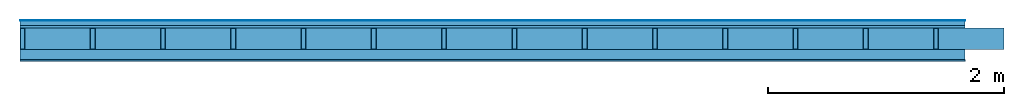
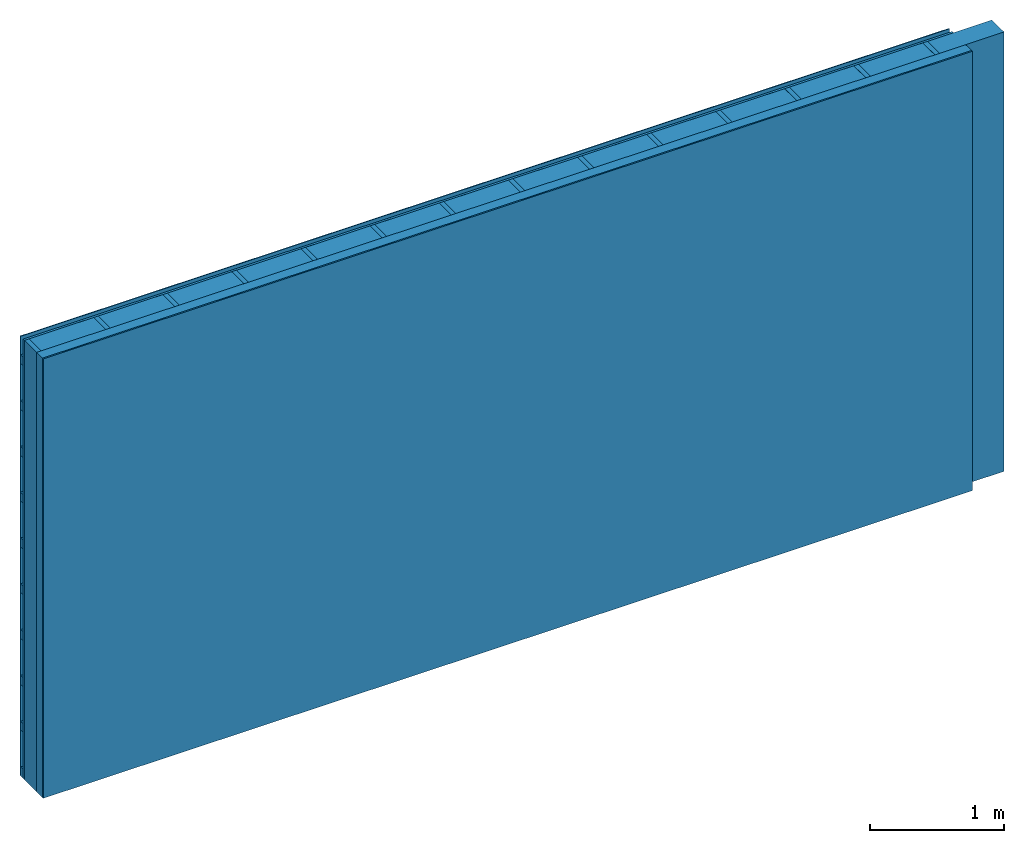
# One storey: 4 plates, 3 members, 1 element without a shape of its own.
"""IFC4 building model written with IfcOpenShell, lengths in metres."""

import ifcopenshell
import ifcopenshell.guid

model = None  # the IFC model being written
_history = None  # IfcOwnerHistory: only IFC2X3 demands one
_inside = {}  # id of a spatial element -> (the spatial element, [elements in it])
_under = {}  # id of a project, library or spatial element -> (it, [spatial elements below it])
_declared = {}  # id of a project -> (the project, [libraries it declares])
_typed = {}  # id of a type object -> (the type object, [elements of that type])
_made_of = {}  # id of a material, layer set ... -> (it, [elements and type objects made of it])


def new_model(schema):
    """Start an empty IFC model of exactly this schema.

    Asked for "IFC4X3", IfcOpenShell would pick the latest addendum, in which some entities
    have other attributes; the version numbers below select the first issue.
    IFC2X3 requires an IfcOwnerHistory on every rooted entity: one is made here for all.
    """
    global model, _history
    if schema == "IFC4X3":
        model = ifcopenshell.file(schema_version=(4, 3, 0, 0))
    else:
        model = ifcopenshell.file(schema=schema)
    _inside.clear()
    _under.clear()
    _declared.clear()
    _typed.clear()
    _made_of.clear()
    _history = None
    if model.schema == "IFC2X3":
        org = make("IfcOrganization", Name="unknown")
        user = make(
            "IfcPersonAndOrganization",
            ThePerson=make("IfcPerson", FamilyName="unknown"),
            TheOrganization=org,
        )
        app = make(
            "IfcApplication",
            ApplicationDeveloper=org,
            Version="unknown",
            ApplicationFullName="unknown",
            ApplicationIdentifier="unknown",
        )
        _history = make(
            "IfcOwnerHistory",
            OwningUser=user,
            OwningApplication=app,
            ChangeAction="ADDED",
            CreationDate=0,
        )
    return model


def make(cls, **values):
    """One entity of the class cls with the attributes given. An attribute that is None is left unset."""
    return model.create_entity(
        cls, **{name: value for name, value in values.items() if value is not None}
    )


def rooted(cls, **values):
    """An entity with a GlobalId (a new one), such as an element, a storey or a relation."""
    return make(cls, GlobalId=ifcopenshell.guid.new(), OwnerHistory=_history, **values)


def si_unit(unit_type, name, prefix=None):
    """IfcSIUnit, for example si_unit("LENGTHUNIT", "METRE", prefix="MILLI")."""
    return make("IfcSIUnit", UnitType=unit_type, Prefix=prefix, Name=name)


def derived_unit(unit_type, elements):
    """IfcDerivedUnit: a product of units, each with its exponent."""
    return make(
        "IfcDerivedUnit",
        Elements=[
            make("IfcDerivedUnitElement", Unit=unit, Exponent=power)
            for unit, power in elements
        ],
        UnitType=unit_type,
    )


def assignment(units):
    """IfcUnitAssignment: the units of a project."""
    return None if units is None else make("IfcUnitAssignment", Units=units)


def point(xyz):
    """IfcCartesianPoint."""
    return None if xyz is None else make("IfcCartesianPoint", Coordinates=xyz)


def direction(xyz):
    """IfcDirection."""
    return None if xyz is None else make("IfcDirection", DirectionRatios=xyz)


def frame(location, z_axis=None, x_axis=None):
    """IfcAxis2Placement3D, a coordinate frame: its origin and axes. An axis left out is left unset."""
    return make(
        "IfcAxis2Placement3D",
        Location=point(location),
        Axis=direction(z_axis),
        RefDirection=direction(x_axis),
    )


def frame_2d(location, x_axis=None):
    """IfcAxis2Placement2D, a coordinate frame in the plane: its origin and x axis."""
    return make(
        "IfcAxis2Placement2D", Location=point(location), RefDirection=direction(x_axis)
    )


def origin():
    """The frame at (0, 0, 0) with its axes left unset."""
    return frame((0.0, 0.0, 0.0))


def origin_with_axes():
    """The frame at (0, 0, 0) with the z axis (0, 0, 1) and the x axis (1, 0, 0) written out."""
    return frame((0.0, 0.0, 0.0), z_axis=(0.0, 0.0, 1.0), x_axis=(1.0, 0.0, 0.0))


def place(relative_to, where):
    """IfcLocalPlacement: puts the frame where relative to a parent placement (None: the world)."""
    return make(
        "IfcLocalPlacement", PlacementRelTo=relative_to, RelativePlacement=where
    )


def context(
    kind, dimensions, precision=None, world=None, true_north=None, identifier=None
):
    """IfcGeometricRepresentationContext, for example the 3D "Model" context."""
    return make(
        "IfcGeometricRepresentationContext",
        ContextIdentifier=identifier,
        ContextType=kind,
        CoordinateSpaceDimension=dimensions,
        Precision=precision,
        WorldCoordinateSystem=world,
        TrueNorth=true_north,
    )


def project(units=None, contexts=None):
    """IfcProject with its units and contexts."""
    return rooted(
        "IfcProject",
        Name="project",
        RepresentationContexts=contexts,
        UnitsInContext=assignment(units),
    )


def spatial(cls, under=None, at=None, **own):
    """A site, building, storey or space (cls), placed at a placement, below another one or the project."""
    s = rooted(cls, ObjectPlacement=at, **own)
    if under is not None:
        _under.setdefault(under.id(), (under, []))[1].append(s)
    return s


def profile(cls, at=None, kind="AREA", **sizes):
    """A parametric profile (cls). Its sizes go by their IFC names, for example OverallWidth=200.0."""
    return make(cls, ProfileType=kind, Position=at, **sizes)


def rectangle(**sizes):
    """IfcRectangleProfileDef."""
    return profile("IfcRectangleProfileDef", **sizes)


def extrude(swept, where, along, depth):
    """IfcExtrudedAreaSolid: the profile swept, set in the frame where, extruded along a direction by depth."""
    return make(
        "IfcExtrudedAreaSolid",
        SweptArea=swept,
        Position=where,
        ExtrudedDirection=direction(along),
        Depth=depth,
    )


def shape(context_of_items, identifier, shape_type, items):
    """IfcShapeRepresentation: the items that make up one representation, for example the "Body"."""
    return make(
        "IfcShapeRepresentation",
        ContextOfItems=context_of_items,
        RepresentationIdentifier=identifier,
        RepresentationType=shape_type,
        Items=items,
    )


def material(Name=None, Category=None):
    """IfcMaterial."""
    return make("IfcMaterial", Name=Name, Category=Category)


def layer(
    of_material, thickness, ventilated=None, Name=None, Category=None, Priority=None
):
    """IfcMaterialLayer: one layer of a wall or slab, of a material (None: an air gap)."""
    return make(
        "IfcMaterialLayer",
        Material=of_material,
        LayerThickness=thickness,
        IsVentilated=ventilated,
        Name=Name,
        Category=Category,
        Priority=Priority,
    )


def layer_set(layers, Name=None):
    """IfcMaterialLayerSet."""
    return make("IfcMaterialLayerSet", MaterialLayers=layers, LayerSetName=Name)


def made_of(thing, what):
    """Note that an element or type object is made of a material, layer set ...; save() writes the relation."""
    if what is not None:
        _made_of.setdefault(what.id(), (what, []))[1].append(thing)
    return thing


def type_object(cls, material=None, **own):
    """A type object (cls), such as IfcWallType, which elements share."""
    return made_of(rooted(cls, **own), material)


def element(
    cls,
    number,
    at=None,
    inside=None,
    cuts=None,
    type_object=None,
    material=None,
    context=None,
    identifier="Body",
    shape_type=None,
    held_by="IfcProductDefinitionShape",
    body=None,
    shapes=None,
    **own,
):
    """One element of the class cls, such as IfcWall. Its Tag is "e" and its number.

    at: its placement. inside: the storey or other place that contains it. cuts: it is an
    opening in that element (IfcRelVoidsElement). A single representation is given by context,
    identifier, shape_type and body (its items); several are given by shapes. held_by: the class
    of the entity that holds the representations. save() writes the other relations.
    """
    e = rooted(cls, Tag="e%d" % number, ObjectPlacement=at, **own)
    if body is not None:
        shapes = [shape(context, identifier, shape_type, body)]
    if shapes is not None:
        e.Representation = make(held_by, Representations=shapes)
    if inside is not None:
        _inside.setdefault(inside.id(), (inside, []))[1].append(e)
    if cuts is not None:
        rooted(
            "IfcRelVoidsElement", RelatingBuildingElement=cuts, RelatedOpeningElement=e
        )
    if type_object is not None:
        _typed.setdefault(type_object.id(), (type_object, []))[1].append(e)
    return made_of(e, material)


def aggregate(whole, parts):
    """IfcRelAggregates: a whole, such as a stair, and the parts it consists of."""
    return rooted("IfcRelAggregates", RelatingObject=whole, RelatedObjects=parts)


def save(model, path):
    """Write the relations noted so far, then the file.

    IfcRelAggregates (storeys below a building ...), IfcRelContainedInSpatialStructure (elements
    in a storey), IfcRelDefinesByType, IfcRelAssociatesMaterial and IfcRelDeclares: one each for
    every whole, place, type object, material and project.
    """
    for whole, parts in _under.values():
        aggregate(whole, parts)
    for where, things in _inside.values():
        rooted(
            "IfcRelContainedInSpatialStructure",
            RelatedElements=things,
            RelatingStructure=where,
        )
    for kind, things in _typed.values():
        rooted("IfcRelDefinesByType", RelatedObjects=things, RelatingType=kind)
    for what, things in _made_of.values():
        rooted("IfcRelAssociatesMaterial", RelatedObjects=things, RelatingMaterial=what)
    for by, libraries in _declared.values():
        rooted("IfcRelDeclares", RelatingContext=by, RelatedDefinitions=libraries)
    model.write(path)


model = new_model("IFC4")

# Units and contexts
plan_context = context("Plan", 3, precision=1e-05, world=origin(), true_north=direction((0.0, 1.0)))
model_context = context("Model", 3, precision=1e-05, world=origin(), true_north=direction((0.0, 1.0)))
ifc_project = project(units=[si_unit("LENGTHUNIT", "METRE"), derived_unit("SOUNDPRESSUREUNIT", [(si_unit("PRESSUREUNIT", "PASCAL", prefix="MICRO"), 0)]), si_unit("ENERGYUNIT", "JOULE", prefix="MEGA"), si_unit("MASSUNIT", "GRAM", prefix="KILO"), derived_unit("THERMALTRANSMITTANCEUNIT", [(si_unit("POWERUNIT", "WATT"), 1), (si_unit("AREAUNIT", "SQUARE_METRE"), -1), (si_unit("THERMODYNAMICTEMPERATUREUNIT", "KELVIN"), -1)]), derived_unit("AREADENSITYUNIT", [(si_unit("MASSUNIT", "GRAM", prefix="KILO"), 1), (si_unit("AREAUNIT", "SQUARE_METRE"), -1)]), derived_unit("USERDEFINED", [(si_unit("ENERGYUNIT", "JOULE", prefix="MEGA"), 1), (si_unit("AREAUNIT", "SQUARE_METRE"), -1)])], contexts=[plan_context, model_context])

# Site, building, storey
site = spatial("IfcSite", under=ifc_project)
building_placement = place(None, origin())
building = spatial("IfcBuilding", under=site, at=building_placement)
storey_placement = place(building_placement, origin())
storey = spatial("IfcBuildingStorey", under=building, at=storey_placement)

# Wall, members, plates
ifc_material_1 = material(Name="mineral, cement-based building board", Category="03.003")
ifc_layer_1 = layer(ifc_material_1, 0.008, Name="Cover 1st layer")
ifc_layer_2 = layer(None, 0.04, Name="Battens / profiles (ventilation)")
ifc_material_2 = material(Category="10.009")
ifc_layer_3 = layer(ifc_material_2, 0.02, Name="outside 1st layer")
ifc_material_3 = material(Name="of the art")
ifc_layer_4 = layer(ifc_material_3, 0.0, Name="Bond")
ifc_layer_5 = layer(None, 0.18, Name="Support")
ifc_layer_6 = layer(ifc_material_3, 0.0, Name="Bond")
ifc_material_4 = material(Name="Solid timber panel")
ifc_layer_7 = layer(ifc_material_4, 0.087, Name="1st layer")
ifc_material_5 = material(Name="Plasterboard type A", Category="03.008")
ifc_layer_8 = layer(ifc_material_5, 0.0125, Name="Covering 1st layer")
ifc_material_6 = material(Name="joints", Category="04.017")
ifc_layer_9 = layer(ifc_material_6, 0.0, Name="Surface")
ifc_layer_set = layer_set([ifc_layer_1, ifc_layer_2, ifc_layer_3, ifc_layer_4, ifc_layer_5, ifc_layer_6, ifc_layer_7, ifc_layer_8, ifc_layer_9])
wall_type = type_object("IfcWallType", Name="D0970", PredefinedType="NOTDEFINED", material=ifc_layer_set)
wall_placement = place(None, frame((0.0, 0.0, 0.0), z_axis=(0.0, -1.0, 0.0), x_axis=(1.0, 0.0, 0.0)))
wall = element("IfcWall", 1, at=wall_placement, inside=storey, type_object=wall_type, material=ifc_layer_set, Name="Wall #1")
ifc_material_7 = material()
member_1_placement = place(wall_placement, origin())
member_1 = element("IfcMember", 2, at=member_1_placement, material=ifc_material_7, Name="Battens / profiles (ventilation)", context=plan_context, shape_type="SweptSolid", body=[
    extrude(rectangle(XDim=0.08, YDim=0.04, at=frame_2d((0.04, 0.02), x_axis=(1.0, 0.0))), frame((0.0, 0.0, 0.008), z_axis=(1.0, 0.0, 0.0), x_axis=(0.0, 1.0, 0.0)), (0.0, 0.0, 1.0), 8.0),
    extrude(rectangle(XDim=0.08, YDim=0.04, at=frame_2d((0.04, 0.02), x_axis=(1.0, 0.0))), frame((0.0, 0.417, 0.008), z_axis=(1.0, 0.0, 0.0), x_axis=(0.0, 1.0, 0.0)), (0.0, 0.0, 1.0), 8.0),
    extrude(rectangle(XDim=0.08, YDim=0.04, at=frame_2d((0.04, 0.02), x_axis=(1.0, 0.0))), frame((0.0, 0.834, 0.008), z_axis=(1.0, 0.0, 0.0), x_axis=(0.0, 1.0, 0.0)), (0.0, 0.0, 1.0), 8.0),
    extrude(rectangle(XDim=0.08, YDim=0.04, at=frame_2d((0.04, 0.02), x_axis=(1.0, 0.0))), frame((0.0, 1.251, 0.008), z_axis=(1.0, 0.0, 0.0), x_axis=(0.0, 1.0, 0.0)), (0.0, 0.0, 1.0), 8.0),
    extrude(rectangle(XDim=0.08, YDim=0.04, at=frame_2d((0.04, 0.02), x_axis=(1.0, 0.0))), frame((0.0, 1.668, 0.008), z_axis=(1.0, 0.0, 0.0), x_axis=(0.0, 1.0, 0.0)), (0.0, 0.0, 1.0), 8.0),
    extrude(rectangle(XDim=0.08, YDim=0.04, at=frame_2d((0.04, 0.02), x_axis=(1.0, 0.0))), frame((0.0, 2.085, 0.008), z_axis=(1.0, 0.0, 0.0), x_axis=(0.0, 1.0, 0.0)), (0.0, 0.0, 1.0), 8.0),
    extrude(rectangle(XDim=0.08, YDim=0.04, at=frame_2d((0.04, 0.02), x_axis=(1.0, 0.0))), frame((0.0, 2.502, 0.008), z_axis=(1.0, 0.0, 0.0), x_axis=(0.0, 1.0, 0.0)), (0.0, 0.0, 1.0), 8.0),
    extrude(rectangle(XDim=0.08, YDim=0.04, at=frame_2d((0.04, 0.02), x_axis=(1.0, 0.0))), frame((0.0, 2.919, 0.008), z_axis=(1.0, 0.0, 0.0), x_axis=(0.0, 1.0, 0.0)), (0.0, 0.0, 1.0), 8.0),
    extrude(rectangle(XDim=0.08, YDim=0.04, at=frame_2d((0.04, 0.02), x_axis=(1.0, 0.0))), frame((0.0, 3.336, 0.008), z_axis=(1.0, 0.0, 0.0), x_axis=(0.0, 1.0, 0.0)), (0.0, 0.0, 1.0), 8.0),
    extrude(rectangle(XDim=0.08, YDim=0.04, at=frame_2d((0.04, 0.02), x_axis=(1.0, 0.0))), frame((0.0, 3.753, 0.008), z_axis=(1.0, 0.0, 0.0), x_axis=(0.0, 1.0, 0.0)), (0.0, 0.0, 1.0), 8.0),
])
ifc_material_8 = material()
member_2_placement = place(wall_placement, origin())
member_2 = element("IfcMember", 3, at=member_2_placement, material=ifc_material_8, Name="Support", context=plan_context, shape_type="SweptSolid", body=[
    extrude(rectangle(XDim=0.04, YDim=0.18, at=frame_2d((0.02, 0.09), x_axis=(1.0, 0.0))), frame((0.0, 4.0, 0.068), z_axis=(0.0, -1.0, 0.0), x_axis=(1.0, 0.0, 0.0)), (0.0, 0.0, 1.0), 4.0),
    extrude(rectangle(XDim=0.04, YDim=0.18, at=frame_2d((0.02, 0.09), x_axis=(1.0, 0.0))), frame((0.595, 4.0, 0.068), z_axis=(0.0, -1.0, 0.0), x_axis=(1.0, 0.0, 0.0)), (0.0, 0.0, 1.0), 4.0),
    extrude(rectangle(XDim=0.04, YDim=0.18, at=frame_2d((0.02, 0.09), x_axis=(1.0, 0.0))), frame((1.19, 4.0, 0.068), z_axis=(0.0, -1.0, 0.0), x_axis=(1.0, 0.0, 0.0)), (0.0, 0.0, 1.0), 4.0),
    extrude(rectangle(XDim=0.04, YDim=0.18, at=frame_2d((0.02, 0.09), x_axis=(1.0, 0.0))), frame((1.785, 4.0, 0.068), z_axis=(0.0, -1.0, 0.0), x_axis=(1.0, 0.0, 0.0)), (0.0, 0.0, 1.0), 4.0),
    extrude(rectangle(XDim=0.04, YDim=0.18, at=frame_2d((0.02, 0.09), x_axis=(1.0, 0.0))), frame((2.38, 4.0, 0.068), z_axis=(0.0, -1.0, 0.0), x_axis=(1.0, 0.0, 0.0)), (0.0, 0.0, 1.0), 4.0),
    extrude(rectangle(XDim=0.04, YDim=0.18, at=frame_2d((0.02, 0.09), x_axis=(1.0, 0.0))), frame((2.975, 4.0, 0.068), z_axis=(0.0, -1.0, 0.0), x_axis=(1.0, 0.0, 0.0)), (0.0, 0.0, 1.0), 4.0),
    extrude(rectangle(XDim=0.04, YDim=0.18, at=frame_2d((0.02, 0.09), x_axis=(1.0, 0.0))), frame((3.57, 4.0, 0.068), z_axis=(0.0, -1.0, 0.0), x_axis=(1.0, 0.0, 0.0)), (0.0, 0.0, 1.0), 4.0),
    extrude(rectangle(XDim=0.04, YDim=0.18, at=frame_2d((0.02, 0.09), x_axis=(1.0, 0.0))), frame((4.165, 4.0, 0.068), z_axis=(0.0, -1.0, 0.0), x_axis=(1.0, 0.0, 0.0)), (0.0, 0.0, 1.0), 4.0),
    extrude(rectangle(XDim=0.04, YDim=0.18, at=frame_2d((0.02, 0.09), x_axis=(1.0, 0.0))), frame((4.76, 4.0, 0.068), z_axis=(0.0, -1.0, 0.0), x_axis=(1.0, 0.0, 0.0)), (0.0, 0.0, 1.0), 4.0),
    extrude(rectangle(XDim=0.04, YDim=0.18, at=frame_2d((0.02, 0.09), x_axis=(1.0, 0.0))), frame((5.355, 4.0, 0.068), z_axis=(0.0, -1.0, 0.0), x_axis=(1.0, 0.0, 0.0)), (0.0, 0.0, 1.0), 4.0),
    extrude(rectangle(XDim=0.04, YDim=0.18, at=frame_2d((0.02, 0.09), x_axis=(1.0, 0.0))), frame((5.95, 4.0, 0.068), z_axis=(0.0, -1.0, 0.0), x_axis=(1.0, 0.0, 0.0)), (0.0, 0.0, 1.0), 4.0),
    extrude(rectangle(XDim=0.04, YDim=0.18, at=frame_2d((0.02, 0.09), x_axis=(1.0, 0.0))), frame((6.545, 4.0, 0.068), z_axis=(0.0, -1.0, 0.0), x_axis=(1.0, 0.0, 0.0)), (0.0, 0.0, 1.0), 4.0),
    extrude(rectangle(XDim=0.04, YDim=0.18, at=frame_2d((0.02, 0.09), x_axis=(1.0, 0.0))), frame((7.14, 4.0, 0.068), z_axis=(0.0, -1.0, 0.0), x_axis=(1.0, 0.0, 0.0)), (0.0, 0.0, 1.0), 4.0),
    extrude(rectangle(XDim=0.04, YDim=0.18, at=frame_2d((0.02, 0.09), x_axis=(1.0, 0.0))), frame((7.735, 4.0, 0.068), z_axis=(0.0, -1.0, 0.0), x_axis=(1.0, 0.0, 0.0)), (0.0, 0.0, 1.0), 4.0),
])
ifc_material_9 = material()
member_3_placement = place(wall_placement, origin())
member_3 = element("IfcMember", 4, at=member_3_placement, material=ifc_material_9, Name="Cavity", context=plan_context, shape_type="SweptSolid", body=[
    extrude(rectangle(XDim=0.555, YDim=0.18, at=frame_2d((0.2775, 0.09), x_axis=(1.0, 0.0))), frame((0.04, 4.0, 0.068), z_axis=(0.0, -1.0, 0.0), x_axis=(1.0, 0.0, 0.0)), (0.0, 0.0, 1.0), 4.0),
    extrude(rectangle(XDim=0.555, YDim=0.18, at=frame_2d((0.2775, 0.09), x_axis=(1.0, 0.0))), frame((0.635, 4.0, 0.068), z_axis=(0.0, -1.0, 0.0), x_axis=(1.0, 0.0, 0.0)), (0.0, 0.0, 1.0), 4.0),
    extrude(rectangle(XDim=0.555, YDim=0.18, at=frame_2d((0.2775, 0.09), x_axis=(1.0, 0.0))), frame((1.23, 4.0, 0.068), z_axis=(0.0, -1.0, 0.0), x_axis=(1.0, 0.0, 0.0)), (0.0, 0.0, 1.0), 4.0),
    extrude(rectangle(XDim=0.555, YDim=0.18, at=frame_2d((0.2775, 0.09), x_axis=(1.0, 0.0))), frame((1.825, 4.0, 0.068), z_axis=(0.0, -1.0, 0.0), x_axis=(1.0, 0.0, 0.0)), (0.0, 0.0, 1.0), 4.0),
    extrude(rectangle(XDim=0.555, YDim=0.18, at=frame_2d((0.2775, 0.09), x_axis=(1.0, 0.0))), frame((2.42, 4.0, 0.068), z_axis=(0.0, -1.0, 0.0), x_axis=(1.0, 0.0, 0.0)), (0.0, 0.0, 1.0), 4.0),
    extrude(rectangle(XDim=0.555, YDim=0.18, at=frame_2d((0.2775, 0.09), x_axis=(1.0, 0.0))), frame((3.015, 4.0, 0.068), z_axis=(0.0, -1.0, 0.0), x_axis=(1.0, 0.0, 0.0)), (0.0, 0.0, 1.0), 4.0),
    extrude(rectangle(XDim=0.555, YDim=0.18, at=frame_2d((0.2775, 0.09), x_axis=(1.0, 0.0))), frame((3.61, 4.0, 0.068), z_axis=(0.0, -1.0, 0.0), x_axis=(1.0, 0.0, 0.0)), (0.0, 0.0, 1.0), 4.0),
    extrude(rectangle(XDim=0.555, YDim=0.18, at=frame_2d((0.2775, 0.09), x_axis=(1.0, 0.0))), frame((4.205, 4.0, 0.068), z_axis=(0.0, -1.0, 0.0), x_axis=(1.0, 0.0, 0.0)), (0.0, 0.0, 1.0), 4.0),
    extrude(rectangle(XDim=0.555, YDim=0.18, at=frame_2d((0.2775, 0.09), x_axis=(1.0, 0.0))), frame((4.8, 4.0, 0.068), z_axis=(0.0, -1.0, 0.0), x_axis=(1.0, 0.0, 0.0)), (0.0, 0.0, 1.0), 4.0),
    extrude(rectangle(XDim=0.555, YDim=0.18, at=frame_2d((0.2775, 0.09), x_axis=(1.0, 0.0))), frame((5.395, 4.0, 0.068), z_axis=(0.0, -1.0, 0.0), x_axis=(1.0, 0.0, 0.0)), (0.0, 0.0, 1.0), 4.0),
    extrude(rectangle(XDim=0.555, YDim=0.18, at=frame_2d((0.2775, 0.09), x_axis=(1.0, 0.0))), frame((5.99, 4.0, 0.068), z_axis=(0.0, -1.0, 0.0), x_axis=(1.0, 0.0, 0.0)), (0.0, 0.0, 1.0), 4.0),
    extrude(rectangle(XDim=0.555, YDim=0.18, at=frame_2d((0.2775, 0.09), x_axis=(1.0, 0.0))), frame((6.585, 4.0, 0.068), z_axis=(0.0, -1.0, 0.0), x_axis=(1.0, 0.0, 0.0)), (0.0, 0.0, 1.0), 4.0),
    extrude(rectangle(XDim=0.555, YDim=0.18, at=frame_2d((0.2775, 0.09), x_axis=(1.0, 0.0))), frame((7.18, 4.0, 0.068), z_axis=(0.0, -1.0, 0.0), x_axis=(1.0, 0.0, 0.0)), (0.0, 0.0, 1.0), 4.0),
    extrude(rectangle(XDim=0.555, YDim=0.18, at=frame_2d((0.2775, 0.09), x_axis=(1.0, 0.0))), frame((7.775, 4.0, 0.068), z_axis=(0.0, -1.0, 0.0), x_axis=(1.0, 0.0, 0.0)), (0.0, 0.0, 1.0), 4.0),
])
plate_1_placement = place(wall_placement, origin())
plate_1 = element("IfcPlate", 5, at=plate_1_placement, material=ifc_material_1, Name="Cover 1st layer", context=plan_context, shape_type="SweptSolid", body=[
    extrude(rectangle(XDim=8.0, YDim=4.0, at=frame_2d((4.0, 2.0), x_axis=(1.0, 0.0))), origin_with_axes(), (0.0, 0.0, 1.0), 0.008),
])
plate_2_placement = place(wall_placement, origin())
plate_2 = element("IfcPlate", 6, at=plate_2_placement, material=ifc_material_2, Name="outside 1st layer", context=plan_context, shape_type="SweptSolid", body=[
    extrude(rectangle(XDim=8.0, YDim=4.0, at=frame_2d((4.0, 2.0), x_axis=(1.0, 0.0))), frame((0.0, 0.0, 0.048), z_axis=(0.0, 0.0, 1.0), x_axis=(1.0, 0.0, 0.0)), (0.0, 0.0, 1.0), 0.02),
])
plate_3_placement = place(wall_placement, origin())
plate_3 = element("IfcPlate", 7, at=plate_3_placement, material=ifc_material_4, Name="1st layer", context=plan_context, shape_type="SweptSolid", body=[
    extrude(rectangle(XDim=8.0, YDim=4.0, at=frame_2d((4.0, 2.0), x_axis=(1.0, 0.0))), frame((0.0, 0.0, 0.248), z_axis=(0.0, 0.0, 1.0), x_axis=(1.0, 0.0, 0.0)), (0.0, 0.0, 1.0), 0.087),
])
plate_4_placement = place(wall_placement, origin())
plate_4 = element("IfcPlate", 8, at=plate_4_placement, material=ifc_material_5, Name="Covering 1st layer", context=plan_context, shape_type="SweptSolid", body=[
    extrude(rectangle(XDim=8.0, YDim=4.0, at=frame_2d((4.0, 2.0), x_axis=(1.0, 0.0))), frame((0.0, 0.0, 0.335), z_axis=(0.0, 0.0, 1.0), x_axis=(1.0, 0.0, 0.0)), (0.0, 0.0, 1.0), 0.0125),
])
aggregate(wall, [plate_1, member_1, plate_2, member_2, member_3, plate_3, plate_4])

save(model, "model.ifc")
